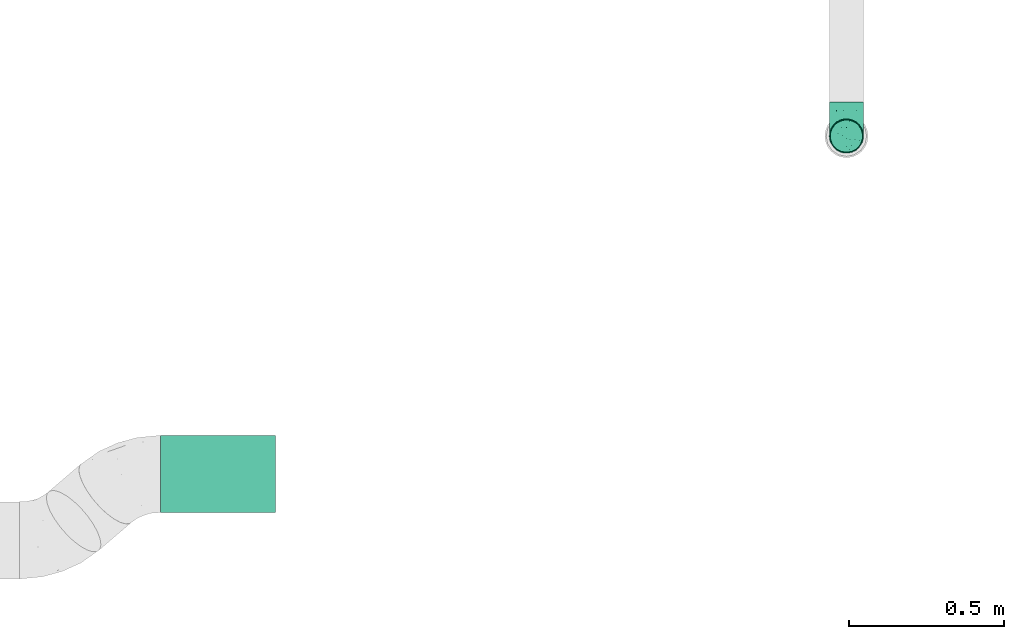
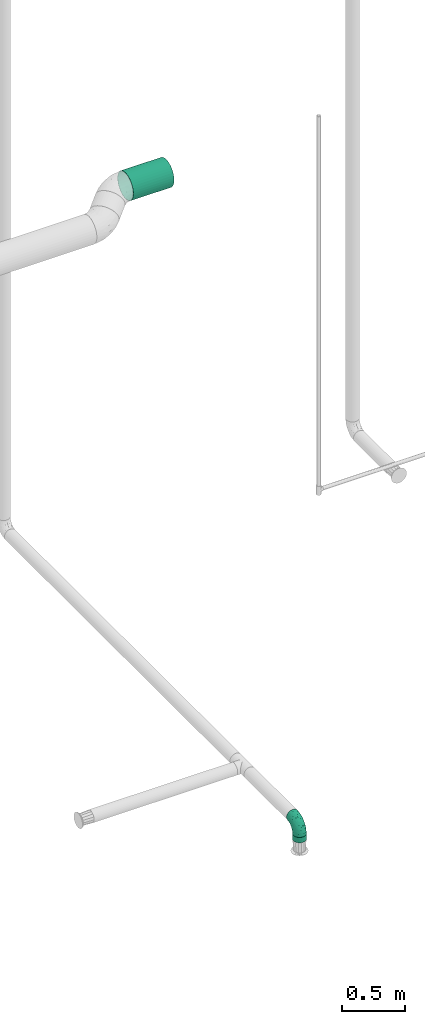
# One storey, part 58 of 123: 2 flow segments, 1 flow fitting.
"""IFC2X3 building model written with IfcOpenShell, lengths in millimetres."""

from ifc_helpers import new_model, entity, si_unit, converted_unit, derived_unit, direction, frame, origin_with_axes, origin_2d_with_axis, place, context, subcontext, project, spatial, hollow_circle, extrude, open_shell, surface_model, source, transform, mapped, material, layer, layer_set, layer_usage, type_object, element, save


model = new_model("IFC2X3")

# Units and contexts
model_context = context("Model", 3, precision=1e-05, world=origin_with_axes(), true_north=direction((0.0, 1.0)))
body_context = subcontext(model_context, "Body", "Model", "MODEL_VIEW")
ifc_project = project(units=[si_unit("AREAUNIT", "SQUARE_METRE"), si_unit("VOLUMEUNIT", "CUBIC_METRE", prefix="DECI"), si_unit("TIMEUNIT", "SECOND"), si_unit("THERMODYNAMICTEMPERATUREUNIT", "DEGREE_CELSIUS"), si_unit("PRESSUREUNIT", "PASCAL"), si_unit("MASSUNIT", "GRAM", prefix="KILO"), si_unit("LENGTHUNIT", "METRE", prefix="MILLI"), si_unit("POWERUNIT", "WATT"), si_unit("ELECTRICCURRENTUNIT", "AMPERE"), si_unit("ELECTRICVOLTAGEUNIT", "VOLT"), derived_unit("VOLUMETRICFLOWRATEUNIT", [(si_unit("VOLUMEUNIT", "CUBIC_METRE", prefix="DECI"), 1), (si_unit("TIMEUNIT", "SECOND"), -1)]), derived_unit("LINEARVELOCITYUNIT", [(si_unit("LENGTHUNIT", "METRE"), 1), (si_unit("TIMEUNIT", "SECOND"), -1)]), derived_unit("MASSDENSITYUNIT", [(si_unit("MASSUNIT", "GRAM", prefix="KILO"), 1), (si_unit("VOLUMEUNIT", "CUBIC_METRE"), -1)]), converted_unit("PLANEANGLEUNIT", "DEGREE", entity("IfcRatioMeasure", 0.01745), si_unit("PLANEANGLEUNIT", "RADIAN"), dimensions=[0, 0, 0, 0, 0, 0, 0])], contexts=[model_context])

# Site, building, storey
site_placement = place(None, origin_with_axes())
site = spatial("IfcSite", under=ifc_project, at=site_placement, CompositionType="ELEMENT")
building_placement = place(site_placement, origin_with_axes())
building = spatial("IfcBuilding", under=site, at=building_placement, Name="mc-building", CompositionType="ELEMENT")
storey_placement = place(building_placement, origin_with_axes())
storey = spatial("IfcBuildingStorey", under=building, at=storey_placement, Name="1. Korrus", CompositionType="ELEMENT", Elevation=0.0)

# Flow segment
ifc_material = material(Name="FZ1")
ifc_layer = layer(ifc_material, 0.0)
ifc_layer_set = layer_set([ifc_layer], Name="FZ1")
ifc_layer_usage = layer_usage(ifc_layer_set, "AXIS1", "POSITIVE", 0.0)
duct_segment_type_1 = type_object("IfcDuctSegmentType", PredefinedType="RIGIDSEGMENT")
shared_shape_1 = source(origin_with_axes(), body_context, "Body", "SweptSolid", [
    extrude(hollow_circle(Radius=55.0, WallThickness=2.0, at=origin_2d_with_axis()), frame((0.0, 0.0, 0.0), z_axis=(1.0, 0.0, 0.0), x_axis=(0.0, 1.0, 0.0)), (0.0, 0.0, 1.0), 51.9),
])
flow_segment_1_placement = place(storey_placement, frame((12366.76802, 8983.57591, 2355.0), z_axis=(0.0, 1.0, 0.0), x_axis=(0.0, 0.0, -1.0)))
element("IfcFlowSegment", 1, at=flow_segment_1_placement, inside=storey, type_object=duct_segment_type_1, material=ifc_layer_usage, context=body_context, shape_type="MappedRepresentation", body=[
    mapped(shared_shape_1, transform((0.0, 0.0, 0.0), scale=1.0)),
])

# Flow fitting
duct_fitting_type = type_object("IfcDuctFittingType", Name="BU", PredefinedType="BEND")
shared_shape_2 = source(origin_with_axes(), body_context, "Body", "SurfaceModel", [
    surface_model("IfcShellBasedSurfaceModel", [(-110.0, 0.0, -55.0), (-110.0, -14.23505, -53.12592), (-110.0, 14.23505, -53.12592), (-110.0, 53.12592, 14.23505), (-110.0, 27.5, -47.63139), (-110.0, 38.89087, -38.89087), (-110.0, -55.0, 0.0), (-110.0, -53.12592, 14.23505), (-110.0, -38.89087, -38.89087), (-110.0, -27.5, -47.63139), (-110.0, -53.12592, -14.23505), (-110.0, -47.63139, -27.5), (-110.0, -14.23505, 53.12592), (-110.0, 14.23505, 53.12592), (-110.0, 27.5, 47.63139), (-110.0, -47.63139, 27.5), (-110.0, -38.89087, 38.89087), (-110.0, -27.5, 47.63139), (-110.0, 0.0, 55.0), (-110.0, 55.0, 0.0), (-110.0, 53.12592, -14.23505), (-110.0, 47.63139, -27.5), (-110.0, 47.63139, 27.5), (-110.0, 38.89087, 38.89087), (-14.23505, 110.0, -53.12592), (-55.0, 110.0, 0.0), (0.0, 110.0, -55.0), (-27.5, 110.0, -47.63139), (-38.89087, 110.0, -38.89087), (-47.63139, 110.0, -27.5), (38.89087, 110.0, -38.89087), (53.12592, 110.0, 14.23505), (27.5, 110.0, -47.63139), (14.23505, 110.0, -53.12592), (47.63139, 110.0, -27.5), (53.12592, 110.0, -14.23505), (55.0, 110.0, 0.0), (-53.12592, 110.0, -14.23505), (-53.12592, 110.0, 14.23505), (-47.63139, 110.0, 27.5), (-38.89087, 110.0, 38.89087), (-27.5, 110.0, 47.63139), (0.0, 110.0, 55.0), (-14.23505, 110.0, 53.12592), (38.89087, 110.0, 38.89087), (47.63139, 110.0, 27.5), (27.5, 110.0, 47.63139), (14.23505, 110.0, 53.12592), (-64.21732, 48.68956, 43.63444), (-76.6405, 38.18013, 45.55988), (-60.44912, 32.56953, 51.94617), (-76.00813, 5.38378, 55.0), (-90.15553, 11.94394, 54.09138), (-78.5998, 26.77405, 50.81338), (-70.18771, 18.55163, 54.03432), (-75.55424, 54.2118, 32.41257), (-93.27622, 45.77614, 33.48188), (-96.12334, 22.13664, 50.81337), (-21.00813, 45.34362, 55.0), (-18.36258, 70.48427, 54.04484), (-32.04182, 59.64019, 52.24446), (-63.88653, 74.77858, 17.99134), (-74.66383, 63.08407, 19.92123), (-63.60674, 66.07878, 29.97482), (-99.597, 52.72185, 18.52927), (-93.11138, 56.59448, 10.50359), (-98.21577, 57.34403, 0.0), (-53.42855, 92.60092, 21.04759), (-88.54852, 54.8376, 21.04759), (-11.86161, 90.23965, 54.10313), (-5.38378, 76.00813, 55.0), (-57.34403, 98.21577, 0.0), (-56.64619, 93.12774, 10.22088), (-45.34362, 21.00813, 55.0), (-44.60838, 44.60838, 52.13415), (-92.68484, 35.46673, 43.63443), (-22.25266, 95.40765, 50.81337), (-35.97783, 90.61597, 43.63443), (-43.70931, 69.58671, 44.47149), (-27.23711, 77.39884, 50.81337), (-57.2828, 79.3123, 24.9774), (-58.67786, 84.31125, 16.04456), (-82.93277, 60.36161, 12.91784), (-49.88337, 54.51816, 47.224), (-74.57753, 66.83759, 9.55742), (-45.35812, 94.97281, 33.48188), (-59.18663, 88.95241, 0.0), (-51.517, 78.6292, 33.48188), (-65.14788, 80.03077, 0.0), (-56.45322, 62.06476, 39.63545), (-88.95241, 59.18663, 0.0), (-71.10913, 71.10913, 0.0), (-80.03077, 65.14788, 0.0), (-94.9309, 45.36788, -33.48188), (-93.11358, 56.60141, -10.46614), (-99.64997, 52.79499, -18.30015), (-90.20425, 36.08686, -43.63443), (-79.99933, 46.56772, -37.92748), (-76.00813, 5.38378, -55.0), (-72.75364, 19.68651, -53.60527), (-45.34362, 21.00813, -55.0), (-21.91957, 65.12078, -53.85897), (-5.38378, 76.00813, -55.0), (-21.00813, 45.34362, -55.0), (-35.41876, 92.89265, -43.63443), (-91.10309, 11.02766, -54.21832), (-45.77614, 93.27622, -33.48188), (-90.50474, 23.21022, -50.81337), (-70.92854, 33.31794, -49.51754), (-78.52933, 63.35627, -11.73997), (-24.91508, 84.05606, -50.81337), (-88.78941, 54.74452, -21.04759), (-69.59921, 57.34866, -33.48187), (-73.36422, 62.46673, -22.94182), (-63.49062, 67.59111, -28.46929), (-56.59448, 93.11138, -10.50359), (-54.8376, 88.54852, -21.04759), (-54.10679, 75.85581, -32.31867), (-57.75956, 31.09612, -52.80882), (-52.72185, 99.597, -18.52927), (-12.62913, 89.46304, -53.99097), (-34.46825, 66.46123, -50.04329), (-43.9837, 43.9837, -52.42279), (-65.78527, 72.58348, -17.68796), (-70.34468, 43.65295, -44.21951), (-57.47001, 51.99467, -44.91465), (-60.72547, 82.29174, -12.88567), (-42.34915, 74.24548, -43.63444), (-57.25194, 63.5016, -38.08211), (-80.95344, 53.56991, -29.32027), (-52.32891, 4.55257, -54.0482), (32.52942, 47.13398, -30.48571), (14.88266, 20.92917, -33.7947), (14.95561, 36.05775, -42.26543), (30.24048, 70.09027, -41.7461), (19.3559, 65.35825, -48.00507), (-70.35075, -46.44478, -19.5952), (-47.13398, -32.52942, -30.48571), (-28.49299, -30.5778, -16.4009), (-4.55257, 52.32891, -54.0482), (-22.4954, 22.4954, -53.25347), (-75.47368, -11.22546, -52.60718), (-81.32209, -51.5606, -9.98467), (-80.81763, -41.84862, -32.14655), (-70.09027, -30.24048, -41.7461), (-36.05774, -14.95561, -42.26543), (-9.15831, -10.852, -27.8997), (-65.35825, -19.3559, -48.00507), (11.22546, 75.47368, -52.60718), (3.94376, 43.9333, -50.53315), (-13.39742, 13.39743, -48.13058), (-43.9333, -3.94376, -50.53315), (49.37776, 67.29486, 0.0), (41.8609, 47.82256, -9.92641), (50.20582, 74.51695, -9.9731), (18.93131, 11.7156, -17.56239), (-27.5, -32.89419, 0.0), (-1.23348, -12.25375, -12.18106), (41.84862, 80.81763, -32.14655), (35.70604, 41.31408, -20.38235), (46.44478, 70.35075, -19.5952), (32.89419, 27.5, 0.0), (6.67262, -6.67262, 0.0), (-67.29486, -49.37776, 0.0), (-50.36265, -42.95545, -9.51562), (-5.47251, 5.47251, -39.92906), (-70.35075, -46.44478, 19.5952), (-74.51695, -50.20582, 9.9731), (-41.31407, -35.70604, 20.38235), (-47.13398, -32.52942, 30.48571), (-80.81763, -41.84862, 32.14655), (-4.55257, 52.32891, 54.0482), (11.22546, 75.47368, 52.60718), (-43.9333, -3.94376, 50.53315), (-65.35825, -19.3559, 48.00507), (-36.05774, -14.95561, 42.26543), (-70.09027, -30.24048, 41.7461), (-11.7156, -18.93131, 17.56239), (30.5778, 28.49299, 16.4009), (12.25375, 1.23348, 12.18106), (51.5606, 81.32209, 9.98467), (42.95545, 50.36265, 9.51562), (-75.47368, -11.22546, 52.60718), (-52.32891, 4.55257, 54.0482), (3.94376, 43.9333, 50.53315), (-22.4954, 22.4954, 53.25347), (-13.39742, 13.39743, 48.13058), (10.852, 9.15831, 27.8997), (-20.92916, -14.88266, 33.79469), (-47.82256, -41.8609, 9.92641), (32.52942, 47.13398, 30.48571), (46.44478, 70.35075, 19.5952), (41.84862, 80.81763, 32.14655), (30.24048, 70.09027, 41.7461), (19.3559, 65.35825, 48.00507), (14.95561, 36.05775, 42.26543), (-5.47251, 5.47251, 39.92906)], [open_shell([[[0, 1, 2]], [[2, 3, 4]], [[4, 3, 5]], [[2, 6, 7]], [[8, 6, 9]], [[1, 9, 6]], [[10, 6, 11]], [[8, 11, 6]], [[6, 2, 1]], [[12, 13, 14]], [[15, 2, 7]], [[16, 17, 2]], [[2, 17, 12]], [[12, 18, 13]], [[19, 20, 3]], [[5, 3, 21]], [[20, 21, 3]], [[22, 3, 2]], [[23, 22, 2]], [[12, 14, 2]], [[2, 14, 23]], [[15, 16, 2]], [[24, 25, 26]], [[27, 25, 24]], [[25, 28, 29]], [[28, 25, 27]], [[30, 26, 31]], [[26, 30, 32]], [[32, 33, 26]], [[34, 31, 35]], [[31, 34, 30]], [[35, 31, 36]], [[29, 37, 25]], [[38, 39, 26]], [[39, 40, 26]], [[41, 42, 40]], [[42, 26, 40]], [[42, 41, 43]], [[26, 44, 45]], [[31, 26, 45]], [[26, 46, 44]], [[47, 46, 26]], [[42, 47, 26]], [[25, 38, 26]], [[48, 49, 50]], [[18, 51, 52]], [[53, 54, 50]], [[55, 56, 49]], [[56, 22, 23]], [[13, 57, 14]], [[58, 59, 60]], [[61, 62, 63]], [[3, 64, 65]], [[53, 52, 54]], [[3, 65, 66]], [[67, 39, 38]], [[56, 68, 64]], [[65, 64, 68]], [[69, 59, 70]], [[38, 71, 72]], [[73, 58, 74]], [[75, 49, 56]], [[76, 69, 43]], [[53, 57, 52]], [[77, 78, 79]], [[41, 76, 43]], [[43, 69, 42]], [[55, 68, 56]], [[23, 14, 75]], [[76, 77, 79]], [[80, 67, 81]], [[62, 82, 68]], [[60, 78, 83]], [[62, 84, 82]], [[85, 77, 40]], [[81, 67, 72]], [[86, 72, 71]], [[87, 85, 67]], [[61, 81, 88]], [[77, 41, 40]], [[78, 77, 87]], [[23, 75, 56]], [[83, 89, 48]], [[85, 40, 39]], [[62, 68, 55]], [[89, 87, 63]], [[83, 48, 50]], [[57, 75, 14]], [[49, 75, 53]], [[67, 85, 39]], [[87, 77, 85]], [[63, 62, 55]], [[89, 55, 48]], [[80, 63, 87]], [[66, 65, 90]], [[66, 19, 3]], [[84, 91, 92]], [[92, 90, 82]], [[65, 82, 90]], [[61, 84, 62]], [[92, 82, 84]], [[68, 82, 65]], [[3, 22, 64]], [[56, 64, 22]], [[38, 25, 71]], [[81, 72, 86]], [[38, 72, 67]], [[91, 61, 88]], [[80, 81, 61]], [[63, 80, 61]], [[67, 80, 87]], [[77, 76, 41]], [[79, 59, 69]], [[79, 69, 76]], [[42, 69, 70]], [[60, 59, 79]], [[58, 70, 59]], [[78, 60, 79]], [[58, 60, 74]], [[52, 57, 13]], [[75, 57, 53]], [[18, 52, 13]], [[52, 51, 54]], [[51, 73, 54]], [[50, 73, 74]], [[73, 50, 54]], [[50, 74, 83]], [[60, 83, 74]], [[89, 83, 78]], [[87, 89, 78]], [[55, 89, 63]], [[50, 49, 53]], [[55, 49, 48]], [[81, 86, 88]], [[91, 84, 61]], [[5, 21, 93]], [[90, 94, 66]], [[20, 94, 95]], [[96, 93, 97]], [[98, 99, 100]], [[96, 4, 5]], [[101, 102, 103]], [[28, 27, 104]], [[2, 105, 0]], [[104, 106, 28]], [[99, 105, 107]], [[108, 107, 96]], [[90, 109, 94]], [[107, 2, 4]], [[20, 66, 94]], [[27, 24, 110]], [[109, 111, 94]], [[112, 113, 114]], [[37, 115, 71]], [[116, 106, 117]], [[99, 118, 100]], [[116, 115, 119]], [[37, 119, 115]], [[24, 120, 110]], [[121, 110, 101]], [[119, 106, 116]], [[101, 110, 120]], [[122, 103, 100]], [[117, 123, 116]], [[124, 125, 108]], [[115, 116, 126]], [[106, 29, 28]], [[26, 102, 120]], [[127, 104, 110]], [[97, 124, 96]], [[125, 122, 118]], [[128, 127, 125]], [[96, 5, 93]], [[115, 126, 86]], [[117, 106, 127]], [[111, 113, 129]], [[95, 93, 21]], [[97, 129, 112]], [[110, 104, 27]], [[106, 104, 127]], [[96, 107, 4]], [[99, 107, 108]], [[99, 108, 118]], [[105, 99, 98]], [[112, 114, 128]], [[121, 125, 127]], [[20, 19, 66]], [[109, 90, 92]], [[94, 111, 95]], [[91, 123, 109]], [[129, 113, 112]], [[93, 95, 111]], [[21, 20, 95]], [[71, 115, 86]], [[71, 25, 37]], [[123, 91, 88]], [[126, 116, 123]], [[123, 88, 126]], [[86, 126, 88]], [[37, 29, 119]], [[106, 119, 29]], [[129, 93, 111]], [[124, 112, 125]], [[0, 105, 98]], [[107, 105, 2]], [[125, 118, 108]], [[100, 118, 122]], [[93, 129, 97]], [[113, 111, 109]], [[109, 123, 113]], [[114, 123, 117]], [[123, 114, 113]], [[128, 114, 117]], [[127, 128, 117]], [[112, 128, 125]], [[103, 122, 101]], [[110, 121, 127]], [[101, 122, 121]], [[125, 121, 122]], [[26, 120, 24]], [[101, 120, 102]], [[96, 124, 108]], [[92, 91, 109]], [[112, 124, 97]], [[100, 130, 98]], [[131, 132, 133]], [[32, 134, 135]], [[136, 137, 138]], [[139, 140, 103]], [[98, 141, 0]], [[142, 10, 136]], [[143, 144, 137]], [[6, 10, 142]], [[137, 145, 146]], [[144, 147, 145]], [[143, 136, 11]], [[11, 136, 10]], [[8, 143, 11]], [[148, 149, 139]], [[8, 9, 144]], [[9, 1, 147]], [[130, 141, 98]], [[103, 140, 100]], [[148, 135, 149]], [[150, 151, 140]], [[152, 153, 154]], [[130, 140, 151]], [[148, 26, 33]], [[147, 1, 141]], [[155, 146, 132]], [[156, 138, 157]], [[134, 30, 158]], [[150, 140, 149]], [[158, 30, 34]], [[30, 134, 32]], [[153, 159, 160]], [[131, 160, 159]], [[144, 145, 137]], [[36, 152, 154]], [[146, 138, 137]], [[155, 161, 162]], [[158, 160, 131]], [[133, 149, 135]], [[156, 163, 164]], [[163, 142, 164]], [[139, 103, 102]], [[153, 152, 161]], [[34, 35, 160]], [[162, 157, 155]], [[132, 165, 133]], [[157, 146, 155]], [[140, 130, 100]], [[141, 130, 151]], [[141, 151, 147]], [[141, 1, 0]], [[102, 26, 148]], [[140, 139, 149]], [[102, 148, 139]], [[135, 33, 32]], [[151, 150, 145]], [[9, 147, 144]], [[151, 145, 147]], [[145, 165, 146]], [[135, 148, 33]], [[133, 135, 134]], [[131, 133, 134]], [[133, 165, 150]], [[133, 150, 149]], [[145, 150, 165]], [[132, 131, 159]], [[146, 165, 132]], [[160, 158, 34]], [[134, 158, 131]], [[144, 143, 8]], [[136, 143, 137]], [[155, 153, 161]], [[154, 153, 160]], [[153, 155, 159]], [[132, 159, 155]], [[160, 35, 154]], [[36, 154, 35]], [[164, 136, 138]], [[6, 142, 163]], [[136, 164, 142]], [[156, 164, 138]], [[156, 157, 162]], [[146, 157, 138]], [[15, 7, 166]], [[6, 163, 167]], [[168, 169, 166]], [[166, 169, 170]], [[171, 172, 70]], [[173, 174, 175]], [[17, 176, 174]], [[177, 156, 162]], [[176, 16, 170]], [[170, 16, 15]], [[161, 178, 179]], [[152, 180, 181]], [[182, 173, 183]], [[18, 12, 182]], [[184, 185, 186]], [[183, 185, 73]], [[183, 73, 51]], [[177, 187, 188]], [[189, 168, 166]], [[187, 178, 190]], [[16, 176, 17]], [[161, 152, 181]], [[45, 191, 31]], [[45, 44, 192]], [[192, 191, 45]], [[180, 36, 31]], [[193, 194, 195]], [[46, 47, 194]], [[193, 195, 190]], [[193, 44, 46]], [[172, 42, 70]], [[185, 58, 73]], [[189, 163, 156]], [[163, 189, 167]], [[70, 58, 171]], [[184, 171, 185]], [[169, 188, 175]], [[180, 31, 191]], [[192, 193, 190]], [[191, 190, 178]], [[182, 174, 173]], [[194, 47, 172]], [[190, 195, 187]], [[186, 185, 173]], [[162, 179, 177]], [[188, 196, 175]], [[179, 187, 177]], [[185, 171, 58]], [[172, 171, 184]], [[172, 184, 194]], [[172, 47, 42]], [[51, 18, 182]], [[185, 183, 173]], [[51, 182, 183]], [[174, 12, 17]], [[184, 186, 195]], [[46, 194, 193]], [[184, 195, 194]], [[195, 196, 187]], [[174, 182, 12]], [[175, 174, 176]], [[169, 175, 176]], [[175, 196, 186]], [[175, 186, 173]], [[195, 186, 196]], [[188, 169, 168]], [[187, 196, 188]], [[166, 170, 15]], [[176, 170, 169]], [[193, 192, 44]], [[191, 192, 190]], [[177, 189, 156]], [[167, 189, 166]], [[189, 177, 168]], [[188, 168, 177]], [[166, 7, 167]], [[6, 167, 7]], [[181, 191, 178]], [[36, 180, 152]], [[191, 181, 180]], [[161, 181, 178]], [[161, 179, 162]], [[187, 179, 178]]])]),
])
flow_fitting_placement = place(storey_placement, frame((12366.76802, 8983.57591, 2465.0), z_axis=(1.0, 0.0, 0.0), x_axis=(0.0, -1.0, 0.0)))
element("IfcFlowFitting", 2, at=flow_fitting_placement, inside=storey, type_object=duct_fitting_type, Name="BU", context=body_context, shape_type="MappedRepresentation", body=[
    mapped(shared_shape_2, transform((0.0, 0.0, 0.0), scale=1.0)),
])

# Flow segment
duct_segment_type_2 = type_object("IfcDuctSegmentType", Name="Safe", PredefinedType="RIGIDSEGMENT")
shared_shape_3 = source(origin_with_axes(), body_context, "Body", "SweptSolid", [
    extrude(hollow_circle(Radius=125.0, WallThickness=2.0, at=origin_2d_with_axis()), frame((0.0, 0.0, 0.0), z_axis=(1.0, 0.0, 0.0), x_axis=(0.0, 1.0, 0.0)), (0.0, 0.0, 1.0), 372.0),
])
flow_segment_2_placement = place(storey_placement, frame((10519.25903, 7890.34565, 10044.0), z_axis=(0.0, 0.0, 1.0), x_axis=(-1.0, 0.0, 0.0)))
element("IfcFlowSegment", 3, at=flow_segment_2_placement, inside=storey, type_object=duct_segment_type_2, material=ifc_layer_usage, Name="Safe", context=body_context, shape_type="MappedRepresentation", body=[
    mapped(shared_shape_3, transform((0.0, 0.0, 0.0), scale=1.0)),
])

save(model, "model.ifc")
